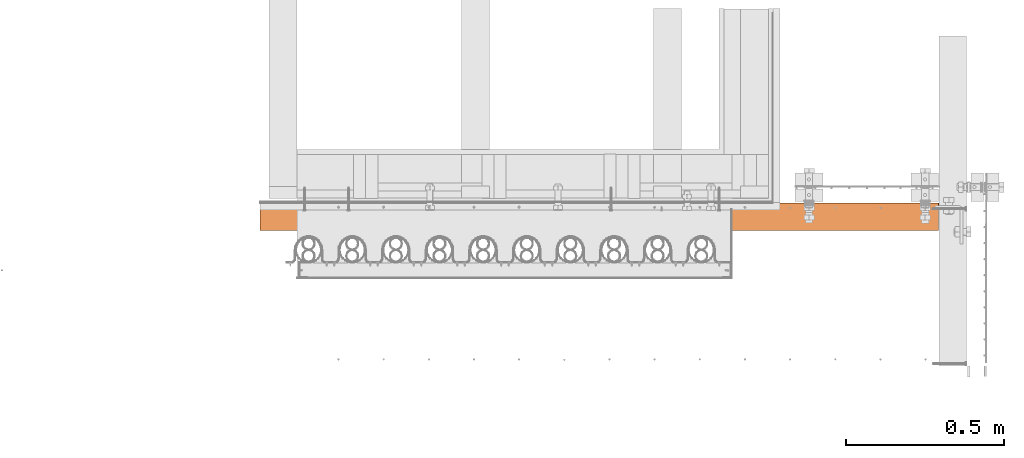
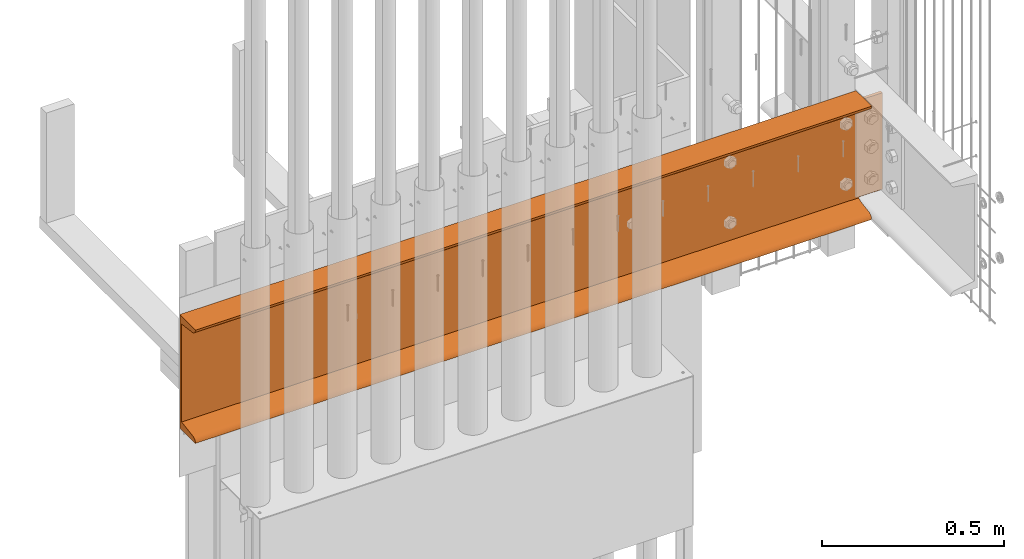
# One storey, part 42 of 44: 1 proxy.
"""IFC4 building model written with IfcOpenShell, lengths in feet."""

from ifc_helpers import new_model, entity, si_unit, converted_unit, derived_unit, direction, frame, origin, place, context, subcontext, project, spatial, source, transform, mapped, material, type_object, type_shapes, element, save


model = new_model("IFC4")

# Units and contexts
model_context = context("Model", 3, precision=0.0001, world=origin(), true_north=direction((6.12303176911189e-17, 1.0)))
body_context = subcontext(model_context, "Body", "Model", "MODEL_VIEW")
ifc_project = project(units=[converted_unit("LENGTHUNIT", "FOOT", entity("IfcRatioMeasure", 0.3048), si_unit("LENGTHUNIT", "METRE"), dimensions=[1, 0, 0, 0, 0, 0, 0]), converted_unit("AREAUNIT", "SQUARE FOOT", entity("IfcRatioMeasure", 0.09290304), si_unit("AREAUNIT", "SQUARE_METRE"), dimensions=[2, 0, 0, 0, 0, 0, 0]), converted_unit("VOLUMEUNIT", "CUBIC FOOT", entity("IfcRatioMeasure", 0.028316846592), si_unit("VOLUMEUNIT", "CUBIC_METRE"), dimensions=[3, 0, 0, 0, 0, 0, 0]), converted_unit("PLANEANGLEUNIT", "DEGREE", entity("IfcRatioMeasure", 0.0174532925199433), si_unit("PLANEANGLEUNIT", "RADIAN"), dimensions=[0, 0, 0, 0, 0, 0, 0]), si_unit("MASSUNIT", "GRAM", prefix="KILO"), derived_unit("MASSDENSITYUNIT", [(si_unit("MASSUNIT", "GRAM", prefix="KILO"), 1), (si_unit("LENGTHUNIT", "METRE"), -3)]), derived_unit("MOMENTOFINERTIAUNIT", [(si_unit("LENGTHUNIT", "METRE"), 4)]), si_unit("TIMEUNIT", "SECOND"), si_unit("FREQUENCYUNIT", "HERTZ"), si_unit("THERMODYNAMICTEMPERATUREUNIT", "DEGREE_CELSIUS"), derived_unit("THERMALTRANSMITTANCEUNIT", [(si_unit("MASSUNIT", "GRAM", prefix="KILO"), 1), (si_unit("THERMODYNAMICTEMPERATUREUNIT", "KELVIN"), -1), (si_unit("TIMEUNIT", "SECOND"), -3)]), derived_unit("VOLUMETRICFLOWRATEUNIT", [(si_unit("LENGTHUNIT", "METRE"), 3), (si_unit("TIMEUNIT", "SECOND"), -1)]), si_unit("ELECTRICCURRENTUNIT", "AMPERE"), si_unit("ELECTRICVOLTAGEUNIT", "VOLT"), si_unit("POWERUNIT", "WATT"), si_unit("FORCEUNIT", "NEWTON"), si_unit("ILLUMINANCEUNIT", "LUX"), si_unit("LUMINOUSFLUXUNIT", "LUMEN"), si_unit("LUMINOUSINTENSITYUNIT", "CANDELA"), derived_unit("USERDEFINED", [(si_unit("MASSUNIT", "GRAM", prefix="KILO"), -1), (si_unit("LENGTHUNIT", "METRE"), -2), (si_unit("TIMEUNIT", "SECOND"), 3), (si_unit("LUMINOUSFLUXUNIT", "LUMEN"), 1)]), derived_unit("LINEARVELOCITYUNIT", [(si_unit("LENGTHUNIT", "METRE"), 1), (si_unit("TIMEUNIT", "SECOND"), -1)]), si_unit("PRESSUREUNIT", "PASCAL"), derived_unit("USERDEFINED", [(si_unit("LENGTHUNIT", "METRE"), -2), (si_unit("MASSUNIT", "GRAM", prefix="KILO"), 1), (si_unit("TIMEUNIT", "SECOND"), -2)]), derived_unit("LINEARFORCEUNIT", [(si_unit("MASSUNIT", "GRAM", prefix="KILO"), 1), (si_unit("LENGTHUNIT", "METRE"), 1), (si_unit("TIMEUNIT", "SECOND"), -2), (si_unit("LENGTHUNIT", "METRE"), -1)]), derived_unit("PLANARFORCEUNIT", [(si_unit("MASSUNIT", "GRAM", prefix="KILO"), 1), (si_unit("LENGTHUNIT", "METRE"), 1), (si_unit("TIMEUNIT", "SECOND"), -2), (si_unit("LENGTHUNIT", "METRE"), -2)])], contexts=[model_context])

# Site, building, storey
site_placement = place(None, origin())
site = spatial("IfcSite", under=ifc_project, at=site_placement, CompositionType="ELEMENT")
building_placement = place(site_placement, origin())
building = spatial("IfcBuilding", under=site, at=building_placement, CompositionType="ELEMENT")
storey_placement = place(building_placement, origin())
storey = spatial("IfcBuildingStorey", under=building, at=storey_placement, CompositionType="ELEMENT", Elevation=0.0)

# Proxy
ifc_material = material(Category="Materials")
building_element_proxy_type = type_object("IfcBuildingElementProxyType", Name="C CHANNEL1:C CHANNEL", PredefinedType="NOTDEFINED", material=ifc_material)
cartesian_point_1 = entity("IfcCartesianPoint", [0.0, 0.289496656023532, 0.00523383279499967])
vertex_point_1 = entity("IfcVertexPoint", cartesian_point_1)
cartesian_point_2 = entity("IfcCartesianPoint", [0.0, 0.00616332269019626, 0.00523383279499967])
vertex_point_2 = entity("IfcVertexPoint", cartesian_point_2)
ifc_direction_1 = entity("IfcDirection", [0.0, -1.0, 0.0])
edge_curve_1 = entity("IfcEdgeCurve", vertex_point_1, vertex_point_2, entity("IfcTrimmedCurve", entity("IfcLine", cartesian_point_1, entity("IfcVector", ifc_direction_1, 1.0)), [cartesian_point_1], [cartesian_point_2], True, "CARTESIAN"), True)
cartesian_point_3 = entity("IfcCartesianPoint", [0.0, 0.0520291397348709, 0.058760682817498])
vertex_point_3 = entity("IfcVertexPoint", cartesian_point_3)
ifc_direction_2 = entity("IfcDirection", [-1.0, 0.0, 0.0])
ifc_direction_3 = entity("IfcDirection", [0.0, 0.0, 1.0])
edge_curve_2 = entity("IfcEdgeCurve", vertex_point_2, vertex_point_3, entity("IfcTrimmedCurve", entity("IfcCircle", entity("IfcAxis2Placement3D", entity("IfcCartesianPoint", [0.0, 0.060329989356867, 0.00523383279499789]), ifc_direction_2, ifc_direction_3), 0.0541666666666707), [cartesian_point_2], [cartesian_point_3], True, "CARTESIAN"), True)
cartesian_point_4 = entity("IfcCartesianPoint", [0.0, 0.256163322690198, 0.0904174523585581])
vertex_point_4 = entity("IfcVertexPoint", cartesian_point_4)
edge_curve_3 = entity("IfcEdgeCurve", vertex_point_3, vertex_point_4, entity("IfcTrimmedCurve", entity("IfcLine", cartesian_point_3, entity("IfcVector", entity("IfcDirection", [0.0, 0.988188000415314, 0.153246454559913]), 1.0)), [cartesian_point_3], [cartesian_point_4], True, "CARTESIAN"), True)
cartesian_point_5 = entity("IfcCartesianPoint", [0.0, 0.256163322690197, 1.17027145655623])
vertex_point_5 = entity("IfcVertexPoint", cartesian_point_5)
edge_curve_4 = entity("IfcEdgeCurve", vertex_point_4, vertex_point_5, entity("IfcTrimmedCurve", entity("IfcLine", cartesian_point_4, entity("IfcVector", ifc_direction_3, 1.0)), [cartesian_point_4], [cartesian_point_5], True, "CARTESIAN"), True)
cartesian_point_6 = entity("IfcCartesianPoint", [0.0, 0.0601262844421431, 1.19711330109155])
vertex_point_6 = entity("IfcVertexPoint", cartesian_point_6)
edge_curve_5 = entity("IfcEdgeCurve", vertex_point_5, vertex_point_6, entity("IfcTrimmedCurve", entity("IfcLine", cartesian_point_5, entity("IfcVector", entity("IfcDirection", [0.0, -0.990755918128503, 0.135656591042773]), 1.0)), [cartesian_point_5], [cartesian_point_6], True, "CARTESIAN"), True)
cartesian_point_7 = entity("IfcCartesianPoint", [0.0, 0.00523383279502188, 1.255233832795])
vertex_point_7 = entity("IfcVertexPoint", cartesian_point_7)
edge_curve_6 = entity("IfcEdgeCurve", vertex_point_6, vertex_point_7, entity("IfcTrimmedCurve", entity("IfcCircle", entity("IfcAxis2Placement3D", entity("IfcCartesianPoint", [0.0, 0.0687726920728764, 1.26026157472021]), ifc_direction_2, ifc_direction_3), 0.0637374680011495), [cartesian_point_6], [cartesian_point_7], True, "CARTESIAN"), True)
cartesian_point_8 = entity("IfcCartesianPoint", [0.0, 0.289496656023528, 1.255233832795])
vertex_point_8 = entity("IfcVertexPoint", cartesian_point_8)
ifc_direction_4 = entity("IfcDirection", [0.0, 1.0, 0.0])
edge_curve_7 = entity("IfcEdgeCurve", vertex_point_7, vertex_point_8, entity("IfcTrimmedCurve", entity("IfcLine", cartesian_point_7, entity("IfcVector", ifc_direction_4, 1.0)), [cartesian_point_7], [cartesian_point_8], True, "CARTESIAN"), True)
ifc_direction_5 = entity("IfcDirection", [0.0, 0.0, -1.0])
edge_curve_8 = entity("IfcEdgeCurve", vertex_point_8, vertex_point_1, entity("IfcTrimmedCurve", entity("IfcLine", cartesian_point_8, entity("IfcVector", ifc_direction_5, 1.0)), [cartesian_point_8], [cartesian_point_1], True, "CARTESIAN"), True)
cartesian_point_9 = entity("IfcCartesianPoint", [7.05382996829303, 0.28949665602351, 0.00523383279499967])
vertex_point_9 = entity("IfcVertexPoint", cartesian_point_9)
ifc_direction_6 = entity("IfcDirection", [1.0, 0.0, 0.0])
edge_curve_9 = entity("IfcEdgeCurve", vertex_point_1, vertex_point_9, entity("IfcTrimmedCurve", entity("IfcLine", cartesian_point_1, entity("IfcVector", ifc_direction_6, 1.0)), [cartesian_point_1], [cartesian_point_9], True, "CARTESIAN"), True)
cartesian_point_10 = entity("IfcCartesianPoint", [7.05382996829303, 0.00616332269017406, 0.00523383279499967])
vertex_point_10 = entity("IfcVertexPoint", cartesian_point_10)
edge_curve_10 = entity("IfcEdgeCurve", vertex_point_9, vertex_point_10, entity("IfcTrimmedCurve", entity("IfcLine", cartesian_point_9, entity("IfcVector", ifc_direction_1, 1.0)), [cartesian_point_9], [cartesian_point_10], True, "CARTESIAN"), True)
edge_curve_11 = entity("IfcEdgeCurve", vertex_point_10, vertex_point_2, entity("IfcTrimmedCurve", entity("IfcLine", cartesian_point_2, entity("IfcVector", ifc_direction_2, 1.0)), [cartesian_point_10], [cartesian_point_2], True, "CARTESIAN"), True)
cartesian_point_11 = entity("IfcCartesianPoint", [7.05382996829303, 0.0520291397348487, 0.058760682817498])
vertex_point_11 = entity("IfcVertexPoint", cartesian_point_11)
edge_curve_12 = entity("IfcEdgeCurve", vertex_point_10, vertex_point_11, entity("IfcTrimmedCurve", entity("IfcCircle", entity("IfcAxis2Placement3D", entity("IfcCartesianPoint", [7.05382996829303, 0.0603299893568447, 0.00523383279499789]), ifc_direction_2, ifc_direction_3), 0.0541666666666707), [cartesian_point_10], [cartesian_point_11], True, "CARTESIAN"), True)
edge_curve_13 = entity("IfcEdgeCurve", vertex_point_11, vertex_point_3, entity("IfcTrimmedCurve", entity("IfcLine", cartesian_point_3, entity("IfcVector", ifc_direction_2, 1.0)), [cartesian_point_11], [cartesian_point_3], True, "CARTESIAN"), True)
cartesian_point_12 = entity("IfcCartesianPoint", [7.05382996829303, 0.143191613266319, 0.0728979986437768])
vertex_point_12 = entity("IfcVertexPoint", cartesian_point_12)
edge_curve_14 = entity("IfcEdgeCurve", vertex_point_11, vertex_point_12, entity("IfcTrimmedCurve", entity("IfcLine", cartesian_point_11, entity("IfcVector", entity("IfcDirection", [0.0, 0.988188000415313, 0.153246454559917]), 1.0)), [cartesian_point_11], [cartesian_point_12], True, "CARTESIAN"), True)
cartesian_point_13 = entity("IfcCartesianPoint", [7.06080863037914, 0.256163322689964, 0.0904174523585244])
vertex_point_13 = entity("IfcVertexPoint", cartesian_point_13)
edge_curve_15 = entity("IfcEdgeCurve", vertex_point_12, vertex_point_13, entity("IfcBSplineCurveWithKnots", 3, [cartesian_point_12, entity("IfcCartesianPoint", [7.05383269217077, 0.15369490746547, 0.0745268310082086]), entity("IfcCartesianPoint", [7.0541351302727, 0.174279623765758, 0.0777190725551744]), entity("IfcCartesianPoint", [7.05549564010835, 0.204361765146851, 0.082384158055385]), entity("IfcCartesianPoint", [7.05771535769759, 0.232236923784531, 0.0867069885590261]), entity("IfcCartesianPoint", [7.05969066222042, 0.248524673128416, 0.0892328640388538]), cartesian_point_13], "UNSPECIFIED", False, "UNKNOWN", [4, 1, 1, 1, 4], [0.0, 0.25, 0.5, 0.75, 1.0], "UNSPECIFIED"), True)
edge_curve_16 = entity("IfcEdgeCurve", vertex_point_13, vertex_point_4, entity("IfcTrimmedCurve", entity("IfcLine", cartesian_point_4, entity("IfcVector", ifc_direction_2, 1.0)), [cartesian_point_13], [cartesian_point_4], True, "CARTESIAN"), True)
cartesian_point_14 = entity("IfcCartesianPoint", [7.07792187921268, 0.256163322690176, 0.0983401853049433])
vertex_point_14 = entity("IfcVertexPoint", cartesian_point_14)
edge_curve_17 = entity("IfcEdgeCurve", vertex_point_13, vertex_point_14, entity("IfcTrimmedCurve", entity("IfcCircle", entity("IfcAxis2Placement3D", entity("IfcCartesianPoint", [7.07930999430596, 0.256163322690176, 0.0728979986437768]), ifc_direction_4, ifc_direction_6), 0.0254800260128286), [cartesian_point_13], [cartesian_point_14], True, "CARTESIAN"), True)
cartesian_point_15 = entity("IfcCartesianPoint", [7.31149807704924, 0.256163322690175, 0.0983401853049557])
vertex_point_15 = entity("IfcVertexPoint", cartesian_point_15)
edge_curve_18 = entity("IfcEdgeCurve", vertex_point_14, vertex_point_15, entity("IfcTrimmedCurve", entity("IfcLine", cartesian_point_14, entity("IfcVector", ifc_direction_6, 1.0)), [cartesian_point_14], [cartesian_point_15], True, "CARTESIAN"), True)
cartesian_point_16 = entity("IfcCartesianPoint", [7.31149807704924, 0.256163322690174, 1.16234872360983])
vertex_point_16 = entity("IfcVertexPoint", cartesian_point_16)
edge_curve_19 = entity("IfcEdgeCurve", vertex_point_15, vertex_point_16, entity("IfcTrimmedCurve", entity("IfcLine", cartesian_point_15, entity("IfcVector", ifc_direction_3, 1.0)), [cartesian_point_15], [cartesian_point_16], True, "CARTESIAN"), True)
cartesian_point_17 = entity("IfcCartesianPoint", [7.07792187921268, 0.256163322690175, 1.16234872360983])
vertex_point_17 = entity("IfcVertexPoint", cartesian_point_17)
edge_curve_20 = entity("IfcEdgeCurve", vertex_point_16, vertex_point_17, entity("IfcTrimmedCurve", entity("IfcLine", cartesian_point_16, entity("IfcVector", ifc_direction_2, 1.0)), [cartesian_point_16], [cartesian_point_17], True, "CARTESIAN"), True)
cartesian_point_18 = entity("IfcCartesianPoint", [7.06080863037914, 0.256163322690175, 1.17027145655626])
vertex_point_18 = entity("IfcVertexPoint", cartesian_point_18)
edge_curve_21 = entity("IfcEdgeCurve", vertex_point_17, vertex_point_18, entity("IfcTrimmedCurve", entity("IfcCircle", entity("IfcAxis2Placement3D", entity("IfcCartesianPoint", [7.07930999430596, 0.256163322690175, 1.187790910271]), ifc_direction_4, ifc_direction_6), 0.0254800260128286), [cartesian_point_17], [cartesian_point_18], True, "CARTESIAN"), True)
edge_curve_22 = entity("IfcEdgeCurve", vertex_point_18, vertex_point_5, entity("IfcTrimmedCurve", entity("IfcLine", cartesian_point_5, entity("IfcVector", ifc_direction_2, 1.0)), [cartesian_point_18], [cartesian_point_5], True, "CARTESIAN"), True)
cartesian_point_19 = entity("IfcCartesianPoint", [7.05382996829303, 0.128211541528077, 1.18779091027101])
vertex_point_19 = entity("IfcVertexPoint", cartesian_point_19)
edge_curve_23 = entity("IfcEdgeCurve", vertex_point_18, vertex_point_19, entity("IfcBSplineCurveWithKnots", 3, [cartesian_point_18, entity("IfcCartesianPoint", [7.05969066222042, 0.24751178663677, 1.17145604487593]), entity("IfcCartesianPoint", [7.05771535769713, 0.229064278403945, 1.17398192035576]), entity("IfcCartesianPoint", [7.0554956401088, 0.197492868038831, 1.1783047508594]), entity("IfcCartesianPoint", [7.05413513027247, 0.163421828567868, 1.18296983635961]), entity("IfcCartesianPoint", [7.053832692171, 0.140107574682792, 1.18616207790658]), cartesian_point_19], "UNSPECIFIED", False, "UNKNOWN", [4, 1, 1, 1, 4], [0.0, 0.25, 0.5, 0.75, 1.0], "UNSPECIFIED"), True)
cartesian_point_20 = entity("IfcCartesianPoint", [7.05382996829303, 0.0601262844421218, 1.19711330109155])
vertex_point_20 = entity("IfcVertexPoint", cartesian_point_20)
edge_curve_24 = entity("IfcEdgeCurve", vertex_point_19, vertex_point_20, entity("IfcTrimmedCurve", entity("IfcLine", cartesian_point_19, entity("IfcVector", entity("IfcDirection", [0.0, -0.990755918128504, 0.135656591042771]), 1.0)), [cartesian_point_19], [cartesian_point_20], True, "CARTESIAN"), True)
edge_curve_25 = entity("IfcEdgeCurve", vertex_point_20, vertex_point_6, entity("IfcTrimmedCurve", entity("IfcLine", cartesian_point_6, entity("IfcVector", ifc_direction_2, 1.0)), [cartesian_point_20], [cartesian_point_6], True, "CARTESIAN"), True)
cartesian_point_21 = entity("IfcCartesianPoint", [7.05382996829303, 0.00523383279499967, 1.255233832795])
vertex_point_21 = entity("IfcVertexPoint", cartesian_point_21)
edge_curve_26 = entity("IfcEdgeCurve", vertex_point_20, vertex_point_21, entity("IfcTrimmedCurve", entity("IfcCircle", entity("IfcAxis2Placement3D", entity("IfcCartesianPoint", [7.05382996829303, 0.0687726920728542, 1.26026157472021]), ifc_direction_2, ifc_direction_3), 0.0637374680011495), [cartesian_point_20], [cartesian_point_21], True, "CARTESIAN"), True)
edge_curve_27 = entity("IfcEdgeCurve", vertex_point_21, vertex_point_7, entity("IfcTrimmedCurve", entity("IfcLine", cartesian_point_7, entity("IfcVector", ifc_direction_2, 1.0)), [cartesian_point_21], [cartesian_point_7], True, "CARTESIAN"), True)
cartesian_point_22 = entity("IfcCartesianPoint", [7.05382996829303, 0.289496656023505, 1.255233832795])
vertex_point_22 = entity("IfcVertexPoint", cartesian_point_22)
edge_curve_28 = entity("IfcEdgeCurve", vertex_point_21, vertex_point_22, entity("IfcTrimmedCurve", entity("IfcLine", cartesian_point_21, entity("IfcVector", ifc_direction_4, 1.0)), [cartesian_point_21], [cartesian_point_22], True, "CARTESIAN"), True)
edge_curve_29 = entity("IfcEdgeCurve", vertex_point_22, vertex_point_8, entity("IfcTrimmedCurve", entity("IfcLine", cartesian_point_8, entity("IfcVector", ifc_direction_2, 1.0)), [cartesian_point_22], [cartesian_point_8], True, "CARTESIAN"), True)
cartesian_point_23 = entity("IfcCartesianPoint", [7.05382996829303, 0.289496656023505, 1.18779091027101])
vertex_point_23 = entity("IfcVertexPoint", cartesian_point_23)
edge_curve_30 = entity("IfcEdgeCurve", vertex_point_22, vertex_point_23, entity("IfcTrimmedCurve", entity("IfcLine", cartesian_point_22, entity("IfcVector", ifc_direction_5, 1.0)), [cartesian_point_22], [cartesian_point_23], True, "CARTESIAN"), True)
cartesian_point_24 = entity("IfcCartesianPoint", [7.07792187921268, 0.289496656023505, 1.16234872360981])
vertex_point_24 = entity("IfcVertexPoint", cartesian_point_24)
edge_curve_31 = entity("IfcEdgeCurve", vertex_point_23, vertex_point_24, entity("IfcTrimmedCurve", entity("IfcCircle", entity("IfcAxis2Placement3D", entity("IfcCartesianPoint", [7.07930999430596, 0.289496656023505, 1.187790910271]), ifc_direction_1, ifc_direction_6), 0.0254800260128286), [cartesian_point_23], [cartesian_point_24], True, "CARTESIAN"), True)
cartesian_point_25 = entity("IfcCartesianPoint", [7.31149807704924, 0.289496656023505, 1.16234872360983])
vertex_point_25 = entity("IfcVertexPoint", cartesian_point_25)
edge_curve_32 = entity("IfcEdgeCurve", vertex_point_24, vertex_point_25, entity("IfcTrimmedCurve", entity("IfcLine", cartesian_point_24, entity("IfcVector", ifc_direction_6, 1.0)), [cartesian_point_24], [cartesian_point_25], True, "CARTESIAN"), True)
cartesian_point_26 = entity("IfcCartesianPoint", [7.31149807704924, 0.289496656023509, 0.0983401853049575])
vertex_point_26 = entity("IfcVertexPoint", cartesian_point_26)
edge_curve_33 = entity("IfcEdgeCurve", vertex_point_25, vertex_point_26, entity("IfcTrimmedCurve", entity("IfcLine", cartesian_point_25, entity("IfcVector", ifc_direction_5, 1.0)), [cartesian_point_25], [cartesian_point_26], True, "CARTESIAN"), True)
cartesian_point_27 = entity("IfcCartesianPoint", [7.07792187921268, 0.28949665602351, 0.0983401853049557])
vertex_point_27 = entity("IfcVertexPoint", cartesian_point_27)
edge_curve_34 = entity("IfcEdgeCurve", vertex_point_26, vertex_point_27, entity("IfcTrimmedCurve", entity("IfcLine", cartesian_point_26, entity("IfcVector", ifc_direction_2, 1.0)), [cartesian_point_26], [cartesian_point_27], True, "CARTESIAN"), True)
cartesian_point_28 = entity("IfcCartesianPoint", [7.05382996829303, 0.28949665602351, 0.0728979986437768])
vertex_point_28 = entity("IfcVertexPoint", cartesian_point_28)
edge_curve_35 = entity("IfcEdgeCurve", vertex_point_27, vertex_point_28, entity("IfcTrimmedCurve", entity("IfcCircle", entity("IfcAxis2Placement3D", entity("IfcCartesianPoint", [7.07930999430596, 0.28949665602351, 0.0728979986437768]), ifc_direction_1, ifc_direction_6), 0.0254800260128286), [cartesian_point_27], [cartesian_point_28], True, "CARTESIAN"), True)
edge_curve_36 = entity("IfcEdgeCurve", vertex_point_28, vertex_point_9, entity("IfcTrimmedCurve", entity("IfcLine", cartesian_point_28, entity("IfcVector", ifc_direction_5, 1.0)), [cartesian_point_28], [cartesian_point_9], True, "CARTESIAN"), True)
edge_curve_37 = entity("IfcEdgeCurve", vertex_point_25, vertex_point_16, entity("IfcTrimmedCurve", entity("IfcLine", cartesian_point_25, entity("IfcVector", ifc_direction_1, 1.0)), [cartesian_point_25], [cartesian_point_16], True, "CARTESIAN"), True)
edge_curve_38 = entity("IfcEdgeCurve", vertex_point_15, vertex_point_26, entity("IfcTrimmedCurve", entity("IfcLine", cartesian_point_26, entity("IfcVector", ifc_direction_4, 1.0)), [cartesian_point_15], [cartesian_point_26], True, "CARTESIAN"), True)
edge_curve_39 = entity("IfcEdgeCurve", vertex_point_14, vertex_point_27, entity("IfcTrimmedCurve", entity("IfcLine", cartesian_point_27, entity("IfcVector", ifc_direction_4, 1.0)), [cartesian_point_14], [cartesian_point_27], True, "CARTESIAN"), True)
edge_curve_40 = entity("IfcEdgeCurve", vertex_point_19, vertex_point_23, entity("IfcTrimmedCurve", entity("IfcLine", cartesian_point_23, entity("IfcVector", ifc_direction_4, 1.0)), [cartesian_point_19], [cartesian_point_23], True, "CARTESIAN"), True)
edge_curve_41 = entity("IfcEdgeCurve", vertex_point_28, vertex_point_12, entity("IfcTrimmedCurve", entity("IfcLine", cartesian_point_28, entity("IfcVector", ifc_direction_1, 1.0)), [cartesian_point_28], [cartesian_point_12], True, "CARTESIAN"), True)
edge_curve_42 = entity("IfcEdgeCurve", vertex_point_17, vertex_point_24, entity("IfcTrimmedCurve", entity("IfcLine", cartesian_point_24, entity("IfcVector", ifc_direction_4, 1.0)), [cartesian_point_17], [cartesian_point_24], True, "CARTESIAN"), True)
shared_shape = source(origin(), body_context, "Body", "AdvancedBrep", [
    entity("IfcAdvancedBrep", entity("IfcClosedShell", [entity("IfcAdvancedFace", [entity("IfcFaceOuterBound", entity("IfcEdgeLoop", [entity("IfcOrientedEdge", None, None, edge_curve_1, True), entity("IfcOrientedEdge", None, None, edge_curve_2, True), entity("IfcOrientedEdge", None, None, edge_curve_3, True), entity("IfcOrientedEdge", None, None, edge_curve_4, True), entity("IfcOrientedEdge", None, None, edge_curve_5, True), entity("IfcOrientedEdge", None, None, edge_curve_6, True), entity("IfcOrientedEdge", None, None, edge_curve_7, True), entity("IfcOrientedEdge", None, None, edge_curve_8, True)]), True)], entity("IfcPlane", entity("IfcAxis2Placement3D", cartesian_point_2, ifc_direction_2, ifc_direction_1)), True), entity("IfcAdvancedFace", [entity("IfcFaceOuterBound", entity("IfcEdgeLoop", [entity("IfcOrientedEdge", None, None, edge_curve_1, False), entity("IfcOrientedEdge", None, None, edge_curve_9, True), entity("IfcOrientedEdge", None, None, edge_curve_10, True), entity("IfcOrientedEdge", None, None, edge_curve_11, True)]), True)], entity("IfcPlane", entity("IfcAxis2Placement3D", cartesian_point_1, ifc_direction_5, ifc_direction_6)), True), entity("IfcAdvancedFace", [entity("IfcFaceOuterBound", entity("IfcEdgeLoop", [entity("IfcOrientedEdge", None, None, edge_curve_2, False), entity("IfcOrientedEdge", None, None, edge_curve_11, False), entity("IfcOrientedEdge", None, None, edge_curve_12, True), entity("IfcOrientedEdge", None, None, edge_curve_13, True)]), True)], entity("IfcCylindricalSurface", entity("IfcAxis2Placement3D", entity("IfcCartesianPoint", [7.34483141038254, 0.0603299893568439, 0.00523383279499789]), ifc_direction_2, ifc_direction_3), 0.0541666666666707), True), entity("IfcAdvancedFace", [entity("IfcFaceOuterBound", entity("IfcEdgeLoop", [entity("IfcOrientedEdge", None, None, edge_curve_3, False), entity("IfcOrientedEdge", None, None, edge_curve_13, False), entity("IfcOrientedEdge", None, None, edge_curve_14, True), entity("IfcOrientedEdge", None, None, edge_curve_15, True), entity("IfcOrientedEdge", None, None, edge_curve_16, True)]), True)], entity("IfcPlane", entity("IfcAxis2Placement3D", cartesian_point_3, entity("IfcDirection", [0.0, -0.153246454559913, 0.988188000415314]), ifc_direction_6)), True), entity("IfcAdvancedFace", [entity("IfcFaceOuterBound", entity("IfcEdgeLoop", [entity("IfcOrientedEdge", None, None, edge_curve_4, False), entity("IfcOrientedEdge", None, None, edge_curve_16, False), entity("IfcOrientedEdge", None, None, edge_curve_17, True), entity("IfcOrientedEdge", None, None, edge_curve_18, True), entity("IfcOrientedEdge", None, None, edge_curve_19, True), entity("IfcOrientedEdge", None, None, edge_curve_20, True), entity("IfcOrientedEdge", None, None, edge_curve_21, True), entity("IfcOrientedEdge", None, None, edge_curve_22, True)]), True)], entity("IfcPlane", entity("IfcAxis2Placement3D", cartesian_point_4, ifc_direction_1, ifc_direction_6)), True), entity("IfcAdvancedFace", [entity("IfcFaceOuterBound", entity("IfcEdgeLoop", [entity("IfcOrientedEdge", None, None, edge_curve_5, False), entity("IfcOrientedEdge", None, None, edge_curve_22, False), entity("IfcOrientedEdge", None, None, edge_curve_23, True), entity("IfcOrientedEdge", None, None, edge_curve_24, True), entity("IfcOrientedEdge", None, None, edge_curve_25, True)]), True)], entity("IfcPlane", entity("IfcAxis2Placement3D", cartesian_point_5, entity("IfcDirection", [0.0, -0.135656591042773, -0.990755918128504]), ifc_direction_6)), True), entity("IfcAdvancedFace", [entity("IfcFaceOuterBound", entity("IfcEdgeLoop", [entity("IfcOrientedEdge", None, None, edge_curve_6, False), entity("IfcOrientedEdge", None, None, edge_curve_25, False), entity("IfcOrientedEdge", None, None, edge_curve_26, True), entity("IfcOrientedEdge", None, None, edge_curve_27, True)]), True)], entity("IfcCylindricalSurface", entity("IfcAxis2Placement3D", entity("IfcCartesianPoint", [7.34483141038254, 0.0687726920728533, 1.26026157472021]), ifc_direction_2, ifc_direction_3), 0.0637374680011495), True), entity("IfcAdvancedFace", [entity("IfcFaceOuterBound", entity("IfcEdgeLoop", [entity("IfcOrientedEdge", None, None, edge_curve_7, False), entity("IfcOrientedEdge", None, None, edge_curve_27, False), entity("IfcOrientedEdge", None, None, edge_curve_28, True), entity("IfcOrientedEdge", None, None, edge_curve_29, True)]), True)], entity("IfcPlane", entity("IfcAxis2Placement3D", cartesian_point_7, ifc_direction_3, ifc_direction_6)), True), entity("IfcAdvancedFace", [entity("IfcFaceOuterBound", entity("IfcEdgeLoop", [entity("IfcOrientedEdge", None, None, edge_curve_8, False), entity("IfcOrientedEdge", None, None, edge_curve_29, False), entity("IfcOrientedEdge", None, None, edge_curve_30, True), entity("IfcOrientedEdge", None, None, edge_curve_31, True), entity("IfcOrientedEdge", None, None, edge_curve_32, True), entity("IfcOrientedEdge", None, None, edge_curve_33, True), entity("IfcOrientedEdge", None, None, edge_curve_34, True), entity("IfcOrientedEdge", None, None, edge_curve_35, True), entity("IfcOrientedEdge", None, None, edge_curve_36, True), entity("IfcOrientedEdge", None, None, edge_curve_9, False)]), True)], entity("IfcPlane", entity("IfcAxis2Placement3D", cartesian_point_8, ifc_direction_4, ifc_direction_6)), True), entity("IfcAdvancedFace", [entity("IfcFaceOuterBound", entity("IfcEdgeLoop", [entity("IfcOrientedEdge", None, None, edge_curve_37, True), entity("IfcOrientedEdge", None, None, edge_curve_19, False), entity("IfcOrientedEdge", None, None, edge_curve_38, True), entity("IfcOrientedEdge", None, None, edge_curve_33, False)]), True)], entity("IfcPlane", entity("IfcAxis2Placement3D", entity("IfcCartesianPoint", [7.31149807704924, -8.37005595084792, 1.16234872360985]), ifc_direction_6, ifc_direction_4)), True), entity("IfcAdvancedFace", [entity("IfcFaceOuterBound", entity("IfcEdgeLoop", [entity("IfcOrientedEdge", None, None, edge_curve_38, False), entity("IfcOrientedEdge", None, None, edge_curve_18, False), entity("IfcOrientedEdge", None, None, edge_curve_39, True), entity("IfcOrientedEdge", None, None, edge_curve_34, False)]), True)], entity("IfcPlane", entity("IfcAxis2Placement3D", entity("IfcCartesianPoint", [7.31149807704924, -8.37005595084792, 0.0983401853049717]), ifc_direction_5, ifc_direction_4)), True), entity("IfcAdvancedFace", [entity("IfcFaceOuterBound", entity("IfcEdgeLoop", [entity("IfcOrientedEdge", None, None, edge_curve_40, True), entity("IfcOrientedEdge", None, None, edge_curve_30, False), entity("IfcOrientedEdge", None, None, edge_curve_28, False), entity("IfcOrientedEdge", None, None, edge_curve_26, False), entity("IfcOrientedEdge", None, None, edge_curve_24, False)]), True)], entity("IfcPlane", entity("IfcAxis2Placement3D", entity("IfcCartesianPoint", [7.05382996829303, -8.37005595084792, 1.40134399751351]), ifc_direction_6, ifc_direction_4)), True), entity("IfcAdvancedFace", [entity("IfcFaceOuterBound", entity("IfcEdgeLoop", [entity("IfcOrientedEdge", None, None, edge_curve_41, True), entity("IfcOrientedEdge", None, None, edge_curve_14, False), entity("IfcOrientedEdge", None, None, edge_curve_12, False), entity("IfcOrientedEdge", None, None, edge_curve_10, False), entity("IfcOrientedEdge", None, None, edge_curve_36, False)]), True)], entity("IfcPlane", entity("IfcAxis2Placement3D", entity("IfcCartesianPoint", [7.05382996829303, -8.37005595084792, 0.072897998643791]), ifc_direction_6, ifc_direction_4)), True), entity("IfcAdvancedFace", [entity("IfcFaceOuterBound", entity("IfcEdgeLoop", [entity("IfcOrientedEdge", None, None, edge_curve_40, False), entity("IfcOrientedEdge", None, None, edge_curve_23, False), entity("IfcOrientedEdge", None, None, edge_curve_21, False), entity("IfcOrientedEdge", None, None, edge_curve_42, True), entity("IfcOrientedEdge", None, None, edge_curve_31, False)]), True)], entity("IfcCylindricalSurface", entity("IfcAxis2Placement3D", entity("IfcCartesianPoint", [7.07930999430596, 4.98531116520379, 1.187790910271]), ifc_direction_1, ifc_direction_6), 0.0254800260128286), False), entity("IfcAdvancedFace", [entity("IfcFaceOuterBound", entity("IfcEdgeLoop", [entity("IfcOrientedEdge", None, None, edge_curve_37, False), entity("IfcOrientedEdge", None, None, edge_curve_32, False), entity("IfcOrientedEdge", None, None, edge_curve_42, False), entity("IfcOrientedEdge", None, None, edge_curve_20, False)]), True)], entity("IfcPlane", entity("IfcAxis2Placement3D", entity("IfcCartesianPoint", [7.07792187921268, -8.37005595084792, 1.16234872360985]), ifc_direction_3, ifc_direction_4)), True), entity("IfcAdvancedFace", [entity("IfcFaceOuterBound", entity("IfcEdgeLoop", [entity("IfcOrientedEdge", None, None, edge_curve_41, False), entity("IfcOrientedEdge", None, None, edge_curve_35, False), entity("IfcOrientedEdge", None, None, edge_curve_39, False), entity("IfcOrientedEdge", None, None, edge_curve_17, False), entity("IfcOrientedEdge", None, None, edge_curve_15, False)]), True)], entity("IfcCylindricalSurface", entity("IfcAxis2Placement3D", entity("IfcCartesianPoint", [7.07930999430596, 4.98531116520379, 0.0728979986437679]), ifc_direction_1, ifc_direction_6), 0.0254800260128286), False)])),
])
type_shapes(building_element_proxy_type, [shared_shape])
proxy_placement = place(storey_placement, frame((1486.94745796881, 4.44907671507622, 8.6666866578136)))
element("IfcBuildingElementProxy", 1, at=proxy_placement, inside=storey, type_object=building_element_proxy_type, material=ifc_material, Name="C CHANNEL1:C CHANNEL", ObjectType="C CHANNEL1:C CHANNEL", PredefinedType="NOTDEFINED", context=body_context, shape_type="MappedRepresentation", body=[
    mapped(shared_shape, transform((0.0, 0.0, 0.0), scale=1.0)),
])

save(model, "model.ifc")
